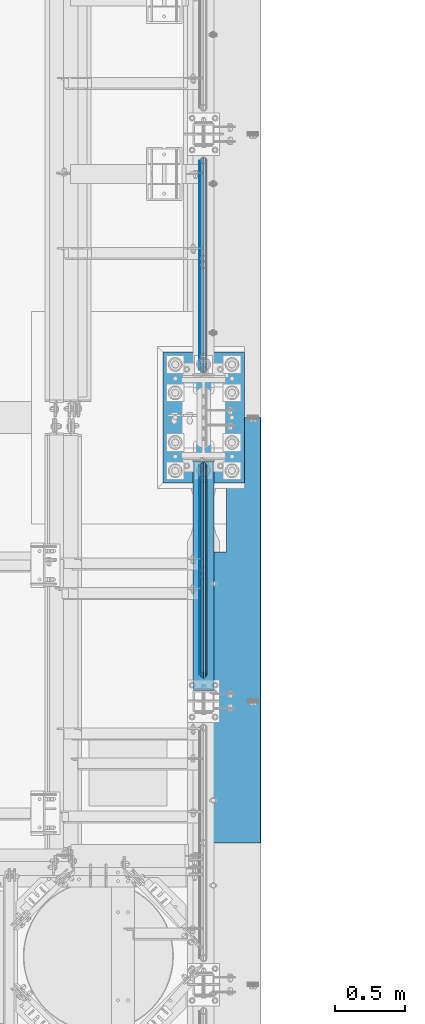
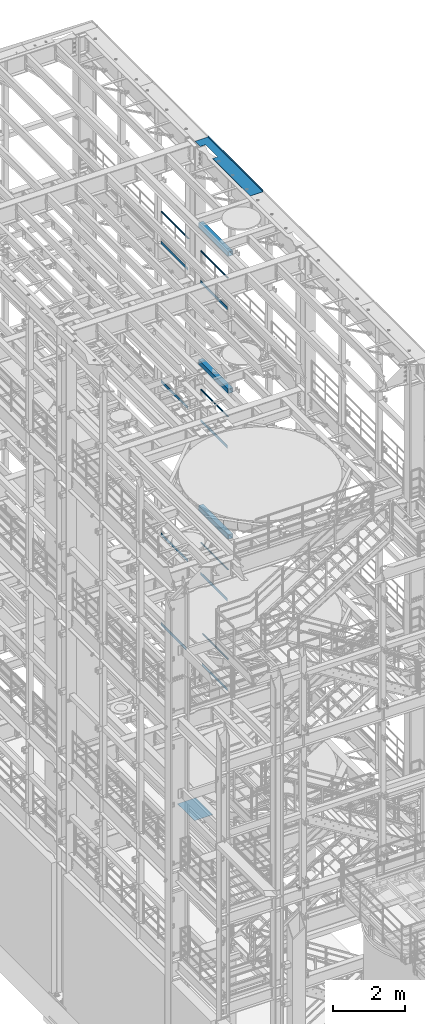
# One storey, part 1076 of 1876: 18 beams, 13 elements without a shape of their own.
"""IFC2X3 building model written with IfcOpenShell, lengths in millimetres."""

from ifc_helpers import new_model, si_unit, frame, origin_with_axes, place, context, subcontext, project, spatial, faceted_brep, material, type_object, element, aggregate, save


model = new_model("IFC2X3")

# Units and contexts
model_context = context("Model", 3, precision=1e-05, world=origin_with_axes())
body_context = subcontext(model_context, "Body", "Model", "MODEL_VIEW")
ifc_project = project(units=[si_unit("LENGTHUNIT", "METRE", prefix="MILLI"), si_unit("AREAUNIT", "SQUARE_METRE"), si_unit("VOLUMEUNIT", "CUBIC_METRE"), si_unit("MASSUNIT", "GRAM", prefix="KILO"), si_unit("TIMEUNIT", "SECOND"), si_unit("PLANEANGLEUNIT", "RADIAN"), si_unit("SOLIDANGLEUNIT", "STERADIAN"), si_unit("THERMODYNAMICTEMPERATUREUNIT", "DEGREE_CELSIUS"), si_unit("LUMINOUSINTENSITYUNIT", "LUMEN")], contexts=[model_context])

# Site, building, storey
site_placement = place(None, origin_with_axes())
site = spatial("IfcSite", under=ifc_project, at=site_placement, CompositionType="ELEMENT")
building_placement = place(site_placement, origin_with_axes())
building = spatial("IfcBuilding", under=site, at=building_placement, Name="Undefined", CompositionType="ELEMENT")
storey_placement = place(building_placement, origin_with_axes())
storey = spatial("IfcBuildingStorey", under=building, at=storey_placement, Name="Undefined", CompositionType="ELEMENT", Elevation=0.0)

# Assembly, beam
assembly_1_placement = place(storey_placement, origin_with_axes())
assembly_1 = element("IfcElementAssembly", 1, at=assembly_1_placement, inside=storey, Name="RAIL", AssemblyPlace="NOTDEFINED", PredefinedType="RIGID_FRAME")
ifc_material_1 = material()
beam_type_1 = type_object("IfcBeamType", Name="PIPE1-1/2SCH40", PredefinedType="NOTDEFINED")
beam_1_placement = place(assembly_1_placement, frame((7620.0, 7940.675, 19059.525), z_axis=(0.0, 0.0, -1.0), x_axis=(0.0, 1.0, 0.0)))
beam_1 = element("IfcBeam", 2, at=beam_1_placement, type_object=beam_type_1, material=ifc_material_1, Name="RAIL", ObjectType="PIPE1-1/2SCH40", context=body_context, shape_type="Brep", body=[
    faceted_brep([(24.1300000000001, -20.4469999999999, 0.0), (34.3535000000002, -17.7076214311803, 10.2235000000001), (1511.8715, -17.7076214311801, 10.2235000000001), (1522.095, -20.4470000000001, 0.0), (41.8376214311802, -10.2235000000001, 17.7076214311819), (1504.38737856882, -10.2235000000001, 17.7076214311819), (44.5770000000002, 0.0, 20.4470000000001), (1501.648, 0.0, 20.4470000000001), (41.8376214311802, 10.2235000000001, 17.7076214311819), (1504.38737856882, 10.2235000000001, 17.7076214311819), (34.3535000000002, 17.7076214311803, 10.2235000000001), (1511.8715, 17.7076214311801, 10.2235000000001), (24.1300000000001, 20.4469999999999, 0.0), (1522.095, 20.4470000000001, 0.0), (13.9065000000001, 17.7076214311803, -10.2235000000001), (1532.3185, 17.7076214311801, -10.2235000000001), (6.42237856882002, 10.2235000000001, -17.7076214311819), (1539.80262143118, 10.2235000000001, -17.7076214311819), (3.68299999999999, 0.0, -20.4470000000001), (1542.542, 0.0, -20.4470000000001), (6.42237856882002, -10.2235000000001, -17.7076214311819), (1539.80262143118, -10.2235000000001, -17.7076214311819), (13.9065000000001, -17.7076214311803, -10.2235000000001), (1532.3185, -17.7076214311801, -10.2235000000001), (24.1299999999854, -24.1299999999992, 0.0), (12.0650000000064, -20.8971929933177, -12.0649999999987), (1534.16, -20.8971929933186, -12.0649999999987), (1522.095, -24.1300000000001, 0.0), (3.23280700668147, -12.0650000000001, -20.8971929933177), (1542.99219299332, -12.0649999999996, -20.8971929933177), (-1.45519152283669e-11, 0.0, -24.130000000001), (1546.225, 0.0, -24.130000000001), (3.23280700668147, 12.0650000000001, -20.8971929933177), (1542.99219299332, 12.0649999999996, -20.8971929933177), (12.0650000000064, 20.8971929933177, -12.0649999999987), (1534.16, 20.8971929933186, -12.0649999999987), (24.1300000000047, 24.1299999999992, 0.0), (1522.095, 24.1300000000001, 0.0), (36.1949999999997, 20.8971929933184, 12.0649999999987), (1510.03, 20.8971929933186, 12.0649999999987), (45.0271929933187, 12.0650000000001, 20.8971929933177), (1501.19780700668, 12.0649999999996, 20.8971929933177), (48.2600000000002, 0.0, 24.130000000001), (1497.965, 0.0, 24.130000000001), (45.0271929933187, -12.0650000000001, 20.8971929933177), (1501.19780700668, -12.0649999999996, 20.8971929933177), (36.1949999999997, -20.8971929933184, 12.0649999999987), (1510.03, -20.8971929933186, 12.0649999999987)], [[[0, 1, 2, 3]], [[1, 4, 5, 2]], [[4, 6, 7, 5]], [[6, 8, 9, 7]], [[8, 10, 11, 9]], [[10, 12, 13, 11]], [[12, 14, 15, 13]], [[14, 16, 17, 15]], [[16, 18, 19, 17]], [[18, 20, 21, 19]], [[20, 22, 23, 21]], [[22, 0, 3, 23]], [[24, 25, 26, 27]], [[25, 28, 29, 26]], [[28, 30, 31, 29]], [[30, 32, 33, 31]], [[32, 34, 35, 33]], [[34, 36, 37, 35]], [[36, 38, 39, 37]], [[38, 40, 41, 39]], [[40, 42, 43, 41]], [[42, 44, 45, 43]], [[44, 46, 47, 45]], [[46, 24, 27, 47]], [[29, 31, 33, 35, 37, 39, 41, 43, 45, 47, 27, 26], [5, 7, 9, 11, 13, 15, 17, 19, 21, 23, 3, 2]], [[46, 44, 42, 40, 38, 36, 34, 32, 30, 28, 25, 24], [22, 20, 18, 16, 14, 12, 10, 8, 6, 4, 1, 0]]]),
])

assembly_2_placement = place(storey_placement, origin_with_axes())
assembly_2 = element("IfcElementAssembly", 3, at=assembly_2_placement, inside=storey, Name="RAIL", AssemblyPlace="NOTDEFINED", PredefinedType="RIGID_FRAME")
beam_2_placement = place(assembly_2_placement, frame((7620.0, 5753.1, 19059.525), z_axis=(0.0, 0.0, -1.0), x_axis=(0.0, 1.0, 0.0)))
beam_2 = element("IfcBeam", 4, at=beam_2_placement, type_object=beam_type_1, material=ifc_material_1, Name="RAIL", ObjectType="PIPE1-1/2SCH40", context=body_context, shape_type="Brep", body=[
    faceted_brep([(24.1300000000001, -20.4469999999999, 0.0), (34.3535000000002, -17.7076214311803, 10.2235000000001), (1511.8715, -17.7076214311801, 10.2235000000001), (1522.095, -20.4470000000001, 0.0), (41.8376214311802, -10.2235000000001, 17.7076214311819), (1504.38737856882, -10.2235000000001, 17.7076214311819), (44.5770000000002, 0.0, 20.4470000000001), (1501.648, 0.0, 20.4470000000001), (41.8376214311802, 10.2235000000001, 17.7076214311819), (1504.38737856882, 10.2235000000001, 17.7076214311819), (34.3535000000002, 17.7076214311803, 10.2235000000001), (1511.8715, 17.7076214311801, 10.2235000000001), (24.1300000000001, 20.4469999999999, 0.0), (1522.095, 20.4470000000001, 0.0), (13.9065000000001, 17.7076214311803, -10.2235000000001), (1532.3185, 17.7076214311801, -10.2235000000001), (6.42237856882002, 10.2235000000001, -17.7076214311819), (1539.80262143118, 10.2235000000001, -17.7076214311819), (3.68299999999999, 0.0, -20.4470000000001), (1542.542, 0.0, -20.4470000000001), (6.42237856882002, -10.2235000000001, -17.7076214311819), (1539.80262143118, -10.2235000000001, -17.7076214311819), (13.9065000000001, -17.7076214311803, -10.2235000000001), (1532.3185, -17.7076214311801, -10.2235000000001), (24.1299999999854, -24.1299999999992, 0.0), (12.0650000000064, -20.8971929933177, -12.0649999999987), (1534.16, -20.8971929933186, -12.0649999999987), (1522.095, -24.1300000000001, 0.0), (3.23280700668147, -12.0650000000001, -20.8971929933177), (1542.99219299332, -12.0649999999996, -20.8971929933177), (-1.45519152283669e-11, 0.0, -24.130000000001), (1546.225, 0.0, -24.130000000001), (3.23280700668147, 12.0650000000001, -20.8971929933177), (1542.99219299332, 12.0649999999996, -20.8971929933177), (12.0650000000064, 20.8971929933177, -12.0649999999987), (1534.16, 20.8971929933186, -12.0649999999987), (24.1300000000047, 24.1299999999992, 0.0), (1522.095, 24.1300000000001, 0.0), (36.1949999999997, 20.8971929933184, 12.0649999999987), (1510.03, 20.8971929933186, 12.0649999999987), (45.0271929933187, 12.0650000000001, 20.8971929933177), (1501.19780700668, 12.0649999999996, 20.8971929933177), (48.2600000000002, 0.0, 24.130000000001), (1497.965, 0.0, 24.130000000001), (45.0271929933187, -12.0650000000001, 20.8971929933177), (1501.19780700668, -12.0649999999996, 20.8971929933177), (36.1949999999997, -20.8971929933184, 12.0649999999987), (1510.03, -20.8971929933186, 12.0649999999987)], [[[0, 1, 2, 3]], [[1, 4, 5, 2]], [[4, 6, 7, 5]], [[6, 8, 9, 7]], [[8, 10, 11, 9]], [[10, 12, 13, 11]], [[12, 14, 15, 13]], [[14, 16, 17, 15]], [[16, 18, 19, 17]], [[18, 20, 21, 19]], [[20, 22, 23, 21]], [[22, 0, 3, 23]], [[24, 25, 26, 27]], [[25, 28, 29, 26]], [[28, 30, 31, 29]], [[30, 32, 33, 31]], [[32, 34, 35, 33]], [[34, 36, 37, 35]], [[36, 38, 39, 37]], [[38, 40, 41, 39]], [[40, 42, 43, 41]], [[42, 44, 45, 43]], [[44, 46, 47, 45]], [[46, 24, 27, 47]], [[29, 31, 33, 35, 37, 39, 41, 43, 45, 47, 27, 26], [5, 7, 9, 11, 13, 15, 17, 19, 21, 23, 3, 2]], [[46, 44, 42, 40, 38, 36, 34, 32, 30, 28, 25, 24], [22, 20, 18, 16, 14, 12, 10, 8, 6, 4, 1, 0]]]),
])

assembly_3_placement = place(storey_placement, origin_with_axes())
assembly_3 = element("IfcElementAssembly", 5, at=assembly_3_placement, inside=storey, Name="RAIL", AssemblyPlace="NOTDEFINED", PredefinedType="RIGID_FRAME")
beam_3_placement = place(assembly_3_placement, frame((7620.0, 5753.1, 14385.925), z_axis=(0.0, 0.0, -1.0), x_axis=(0.0, 1.0, 0.0)))
beam_3 = element("IfcBeam", 6, at=beam_3_placement, type_object=beam_type_1, material=ifc_material_1, Name="RAIL", ObjectType="PIPE1-1/2SCH40", context=body_context, shape_type="Brep", body=[
    faceted_brep([(24.1300000000001, -20.4469999999999, 0.0), (34.3535000000002, -17.7076214311803, 10.2235000000001), (1511.8715, -17.7076214311801, 10.2235000000001), (1522.095, -20.4470000000001, 0.0), (41.8376214311802, -10.2235000000001, 17.7076214311819), (1504.38737856882, -10.2235000000001, 17.7076214311819), (44.5770000000002, 0.0, 20.4470000000001), (1501.648, 0.0, 20.4470000000001), (41.8376214311802, 10.2235000000001, 17.7076214311819), (1504.38737856882, 10.2235000000001, 17.7076214311819), (34.3535000000002, 17.7076214311803, 10.2235000000001), (1511.8715, 17.7076214311801, 10.2235000000001), (24.1300000000001, 20.4469999999999, 0.0), (1522.095, 20.4470000000001, 0.0), (13.9065000000001, 17.7076214311803, -10.2235000000001), (1532.3185, 17.7076214311801, -10.2235000000001), (6.42237856882002, 10.2235000000001, -17.7076214311819), (1539.80262143118, 10.2235000000001, -17.7076214311819), (3.68299999999999, 0.0, -20.4470000000001), (1542.542, 0.0, -20.4470000000001), (6.42237856882002, -10.2235000000001, -17.7076214311819), (1539.80262143118, -10.2235000000001, -17.7076214311819), (13.9065000000001, -17.7076214311803, -10.2235000000001), (1532.3185, -17.7076214311801, -10.2235000000001), (24.1299999999854, -24.1299999999992, 0.0), (12.0650000000064, -20.8971929933177, -12.0649999999987), (1534.16, -20.8971929933186, -12.0649999999987), (1522.095, -24.1300000000001, 0.0), (3.23280700668147, -12.0650000000001, -20.8971929933177), (1542.99219299332, -12.0649999999996, -20.8971929933177), (-1.45519152283669e-11, 0.0, -24.130000000001), (1546.225, 0.0, -24.130000000001), (3.23280700668147, 12.0650000000001, -20.8971929933177), (1542.99219299332, 12.0649999999996, -20.8971929933177), (12.0650000000064, 20.8971929933177, -12.0649999999987), (1534.16, 20.8971929933186, -12.0649999999987), (24.1300000000047, 24.1299999999992, 0.0), (1522.095, 24.1300000000001, 0.0), (36.1949999999997, 20.8971929933184, 12.0649999999987), (1510.03, 20.8971929933186, 12.0649999999987), (45.0271929933187, 12.0650000000001, 20.8971929933177), (1501.19780700668, 12.0649999999996, 20.8971929933177), (48.2600000000002, 0.0, 24.130000000001), (1497.965, 0.0, 24.130000000001), (45.0271929933187, -12.0650000000001, 20.8971929933177), (1501.19780700668, -12.0649999999996, 20.8971929933177), (36.1949999999997, -20.8971929933184, 12.0649999999987), (1510.03, -20.8971929933186, 12.0649999999987)], [[[0, 1, 2, 3]], [[1, 4, 5, 2]], [[4, 6, 7, 5]], [[6, 8, 9, 7]], [[8, 10, 11, 9]], [[10, 12, 13, 11]], [[12, 14, 15, 13]], [[14, 16, 17, 15]], [[16, 18, 19, 17]], [[18, 20, 21, 19]], [[20, 22, 23, 21]], [[22, 0, 3, 23]], [[24, 25, 26, 27]], [[25, 28, 29, 26]], [[28, 30, 31, 29]], [[30, 32, 33, 31]], [[32, 34, 35, 33]], [[34, 36, 37, 35]], [[36, 38, 39, 37]], [[38, 40, 41, 39]], [[40, 42, 43, 41]], [[42, 44, 45, 43]], [[44, 46, 47, 45]], [[46, 24, 27, 47]], [[29, 31, 33, 35, 37, 39, 41, 43, 45, 47, 27, 26], [5, 7, 9, 11, 13, 15, 17, 19, 21, 23, 3, 2]], [[46, 44, 42, 40, 38, 36, 34, 32, 30, 28, 25, 24], [22, 20, 18, 16, 14, 12, 10, 8, 6, 4, 1, 0]]]),
])

assembly_4_placement = place(storey_placement, origin_with_axes())
assembly_4 = element("IfcElementAssembly", 7, at=assembly_4_placement, inside=storey, Name="RAIL", AssemblyPlace="NOTDEFINED", PredefinedType="RIGID_FRAME")
beam_4_placement = place(assembly_4_placement, frame((7620.0, 5753.1, 9229.725), z_axis=(0.0, 0.0, -1.0), x_axis=(0.0, 1.0, 0.0)))
beam_4 = element("IfcBeam", 8, at=beam_4_placement, type_object=beam_type_1, material=ifc_material_1, Name="RAIL", ObjectType="PIPE1-1/2SCH40", context=body_context, shape_type="Brep", body=[
    faceted_brep([(24.1300000000001, -20.4469999999999, 0.0), (34.3535000000002, -17.7076214311803, 10.2235000000001), (1511.8715, -17.7076214311801, 10.2235000000001), (1522.095, -20.4470000000001, 0.0), (41.8376214311802, -10.2235000000001, 17.7076214311819), (1504.38737856882, -10.2235000000001, 17.7076214311819), (44.5770000000002, 0.0, 20.4470000000001), (1501.648, 0.0, 20.4470000000001), (41.8376214311802, 10.2235000000001, 17.7076214311819), (1504.38737856882, 10.2235000000001, 17.7076214311819), (34.3535000000002, 17.7076214311803, 10.2235000000001), (1511.8715, 17.7076214311801, 10.2235000000001), (24.1300000000001, 20.4469999999999, 0.0), (1522.095, 20.4470000000001, 0.0), (13.9065000000001, 17.7076214311803, -10.2235000000001), (1532.3185, 17.7076214311801, -10.2235000000001), (6.42237856882002, 10.2235000000001, -17.7076214311819), (1539.80262143118, 10.2235000000001, -17.7076214311819), (3.68299999999999, 0.0, -20.4470000000001), (1542.542, 0.0, -20.4470000000001), (6.42237856882002, -10.2235000000001, -17.7076214311819), (1539.80262143118, -10.2235000000001, -17.7076214311819), (13.9065000000001, -17.7076214311803, -10.2235000000001), (1532.3185, -17.7076214311801, -10.2235000000001), (24.1299999999854, -24.1299999999992, 0.0), (12.0650000000064, -20.8971929933177, -12.0649999999987), (1534.16, -20.8971929933186, -12.0649999999987), (1522.095, -24.1300000000001, 0.0), (3.23280700668147, -12.0650000000001, -20.8971929933177), (1542.99219299332, -12.0649999999996, -20.8971929933177), (-1.45519152283669e-11, 0.0, -24.130000000001), (1546.225, 0.0, -24.130000000001), (3.23280700668147, 12.0650000000001, -20.8971929933177), (1542.99219299332, 12.0649999999996, -20.8971929933177), (12.0650000000064, 20.8971929933177, -12.0649999999987), (1534.16, 20.8971929933186, -12.0649999999987), (24.1300000000047, 24.1299999999992, 0.0), (1522.095, 24.1300000000001, 0.0), (36.1949999999997, 20.8971929933184, 12.0649999999987), (1510.03, 20.8971929933186, 12.0649999999987), (45.0271929933187, 12.0650000000001, 20.8971929933177), (1501.19780700668, 12.0649999999996, 20.8971929933177), (48.2600000000002, 0.0, 24.130000000001), (1497.965, 0.0, 24.130000000001), (45.0271929933187, -12.0650000000001, 20.8971929933177), (1501.19780700668, -12.0649999999996, 20.8971929933177), (36.1949999999997, -20.8971929933184, 12.0649999999987), (1510.03, -20.8971929933186, 12.0649999999987)], [[[0, 1, 2, 3]], [[1, 4, 5, 2]], [[4, 6, 7, 5]], [[6, 8, 9, 7]], [[8, 10, 11, 9]], [[10, 12, 13, 11]], [[12, 14, 15, 13]], [[14, 16, 17, 15]], [[16, 18, 19, 17]], [[18, 20, 21, 19]], [[20, 22, 23, 21]], [[22, 0, 3, 23]], [[24, 25, 26, 27]], [[25, 28, 29, 26]], [[28, 30, 31, 29]], [[30, 32, 33, 31]], [[32, 34, 35, 33]], [[34, 36, 37, 35]], [[36, 38, 39, 37]], [[38, 40, 41, 39]], [[40, 42, 43, 41]], [[42, 44, 45, 43]], [[44, 46, 47, 45]], [[46, 24, 27, 47]], [[29, 31, 33, 35, 37, 39, 41, 43, 45, 47, 27, 26], [5, 7, 9, 11, 13, 15, 17, 19, 21, 23, 3, 2]], [[46, 44, 42, 40, 38, 36, 34, 32, 30, 28, 25, 24], [22, 20, 18, 16, 14, 12, 10, 8, 6, 4, 1, 0]]]),
])

assembly_5_placement = place(storey_placement, origin_with_axes())
assembly_5 = element("IfcElementAssembly", 9, at=assembly_5_placement, inside=storey, Name="RAIL", AssemblyPlace="NOTDEFINED", PredefinedType="RIGID_FRAME")
beam_5_placement = place(assembly_5_placement, frame((7620.00000000068, 7204.0396633614, 6207.13724280096), z_axis=(0.0, 7.91400000045761e-06, -0.999999999968684), x_axis=(0.0, -0.999999999968684, -7.91400000071008e-06)))
beam_5 = element("IfcBeam", 10, at=beam_5_placement, type_object=beam_type_1, material=ifc_material_1, Name="RAIL", ObjectType="PIPE1-1/2SCH40", context=body_context, shape_type="Brep", body=[
    faceted_brep([(24.1297889306325, -20.4470000000001, 4.54747350886464e-12), (34.3533782626628, -17.7076214311801, 10.223500000001), (1416.58624781054, -17.7076214311801, 10.2235000002374), (1426.80965847928, -20.4470000000001, 2.42835085373372e-10), (41.8375650894295, -10.2235000000001, 17.7076214311801), (1409.10219177439, -10.2235000000001, 17.7076214314138), (44.5770000000002, 0.0, 20.4470000000001), (1406.3628371418, 0.0, 20.4470000002311), (41.8375650894295, 10.2235000000001, 17.7076214311801), (1409.10219177439, 10.2235000000001, 17.7076214314138), (34.3533782626628, 17.7076214311801, 10.223500000001), (1416.58624781054, 17.7076214311801, 10.2235000002374), (24.1297889306325, 20.4470000000001, 4.54747350886464e-12), (1426.80965847928, 20.4470000000001, 2.42835085373372e-10), (13.9061995986012, 17.7076214311801, -10.2234999999919), (1437.03306914802, 17.7076214311801, -10.2234999997499), (6.42201277183449, 10.2235000000001, -17.707621431171), (1444.51712518418, 10.2235000000001, -17.7076214309263), (3.68261026657001, 0.0, -20.4469999999901), (1447.25647981676, 0.0, -20.4469999997445), (6.42201277183449, -10.2235000000001, -17.707621431171), (1444.51712518418, -10.2235000000001, -17.7076214309263), (13.9061995986012, -17.7076214311801, -10.2234999999919), (1437.03306914802, -17.7076214311801, -10.2234999997499), (24.1297889306325, -24.1300000000001, 4.54747350886464e-12), (12.0646835077378, -20.8971929933186, -12.0649999999923), (1438.8745530573, -20.8971929933186, -12.0649999997486), (1426.80965847928, -24.1300000000001, 2.42835085373372e-10), (3.23241333950409, -12.0649999999996, -20.8971929933086), (1447.70666887637, -12.0649999999996, -20.8971929930613), (-0.000421915156039177, 0.0, -24.1299999999892), (1450.93944763532, 0.0, -24.1299999997409), (3.23241333950409, 12.0649999999996, -20.8971929933086), (1447.70666887637, 12.0649999999996, -20.8971929930613), (12.0646835077378, 20.8971929933186, -12.0649999999923), (1438.8745530573, 20.8971929933186, -12.0649999997486), (24.1297889306325, 24.1300000000001, 4.54747350886464e-12), (1426.80965847928, 24.1300000000001, 2.42835085373372e-10), (36.1948943535272, 20.8971929933186, 12.0650000000014), (1414.74476390127, 20.8971929933186, 12.0650000002352), (45.0271929933187, 12.0650000000001, 20.8971929933177), (1405.9126480822, 12.0649999999996, 20.8971929935497), (48.2600000000002, 0.0, 24.130000000001), (1402.67986932325, 0.0, 24.1300000002293), (45.0271929933187, -12.0650000000001, 20.8971929933177), (1405.9126480822, -12.0649999999996, 20.8971929935497), (36.1948943535263, -20.8971929933186, 12.0650000000014), (1414.74476390127, -20.8971929933186, 12.0650000002352)], [[[0, 1, 2, 3]], [[1, 4, 5, 2]], [[4, 6, 7, 5]], [[6, 8, 9, 7]], [[8, 10, 11, 9]], [[10, 12, 13, 11]], [[12, 14, 15, 13]], [[14, 16, 17, 15]], [[16, 18, 19, 17]], [[18, 20, 21, 19]], [[20, 22, 23, 21]], [[22, 0, 3, 23]], [[24, 25, 26, 27]], [[25, 28, 29, 26]], [[28, 30, 31, 29]], [[30, 32, 33, 31]], [[32, 34, 35, 33]], [[34, 36, 37, 35]], [[36, 38, 39, 37]], [[38, 40, 41, 39]], [[40, 42, 43, 41]], [[42, 44, 45, 43]], [[44, 46, 47, 45]], [[46, 24, 27, 47]], [[29, 31, 33, 35, 37, 39, 41, 43, 45, 47, 27, 26], [5, 7, 9, 11, 13, 15, 17, 19, 21, 23, 3, 2]], [[46, 44, 42, 40, 38, 36, 34, 32, 30, 28, 25, 24], [22, 20, 18, 16, 14, 12, 10, 8, 6, 4, 1, 0]]]),
])

assembly_6_placement = place(storey_placement, origin_with_axes())
assembly_6 = element("IfcElementAssembly", 11, at=assembly_6_placement, inside=storey, Name="BEAM", AssemblyPlace="NOTDEFINED", PredefinedType="RIGID_FRAME")
ifc_material_2 = material()
beam_type_2 = type_object("IfcBeamType", Name="HSS6X6X3/8", PredefinedType="NOTDEFINED")
beam_6_placement = place(assembly_6_placement, frame((7620.0, 5588.0, 19958.05), z_axis=(-1.0, 0.0, 0.0), x_axis=(0.0, 1.0, 0.0)))
beam_6 = element("IfcBeam", 12, at=beam_6_placement, type_object=beam_type_2, material=ifc_material_2, Name="BEAM", ObjectType="HSS6X6X3/8", context=body_context, shape_type="Brep", body=[
    faceted_brep([(76.2000000000007, 66.6749999999993, -66.6750000000002), (76.2000000000007, -66.6749999999993, -66.6750000000002), (1720.85, -66.6749999999993, -66.675), (1720.85, 66.6749999999993, -66.675), (76.2000000000007, -66.6749999999993, 66.6750000000002), (1720.85, -66.6749999999993, 66.675), (76.2000000000007, 66.6749999999993, 66.6750000000002), (1720.85, 66.6749999999993, 66.675), (76.2000000000007, 76.2000000000007, -76.1999999999998), (76.2000000000007, 76.2000000000007, 76.1999999999998), (1720.85, 76.2000000000007, 76.2), (1720.85, 76.2000000000007, -76.2), (76.2000000000007, -76.2000000000007, 76.1999999999998), (1720.85, -76.2000000000007, 76.2), (76.2000000000007, -76.2000000000007, -76.1999999999998), (1720.85, -76.2000000000007, -76.2)], [[[0, 1, 2, 3]], [[1, 4, 5, 2]], [[4, 6, 7, 5]], [[6, 0, 3, 7]], [[8, 9, 10, 11]], [[9, 12, 13, 10]], [[12, 14, 15, 13]], [[14, 8, 11, 15]], [[13, 15, 11, 10], [5, 7, 3, 2]], [[14, 12, 9, 8], [6, 4, 1, 0]]]),
])
aggregate(assembly_6, [beam_6])

assembly_7_placement = place(storey_placement, origin_with_axes())
assembly_7 = element("IfcElementAssembly", 13, at=assembly_7_placement, inside=storey, Name="BEAM", AssemblyPlace="NOTDEFINED", PredefinedType="RIGID_FRAME")
beam_7_placement = place(assembly_7_placement, frame((7620.0, 5588.0, 15335.25), z_axis=(-1.0, 0.0, 0.0), x_axis=(0.0, 1.0, 0.0)))
beam_7 = element("IfcBeam", 14, at=beam_7_placement, type_object=beam_type_2, material=ifc_material_2, Name="BEAM", ObjectType="HSS6X6X3/8", context=body_context, shape_type="Brep", body=[
    faceted_brep([(76.2000000000007, 66.6749999999993, -66.6750000000002), (76.2000000000007, -66.6749999999993, -66.6750000000002), (1720.85, -66.6749999999993, -66.675), (1720.85, 66.6749999999993, -66.675), (76.2000000000007, -66.6749999999993, 66.6750000000002), (1720.85, -66.6749999999993, 66.675), (76.2000000000007, 66.6749999999993, 66.6750000000002), (1720.85, 66.6749999999993, 66.675), (76.2000000000007, 76.2000000000007, -76.1999999999998), (76.2000000000007, 76.2000000000007, 76.1999999999998), (1720.85, 76.2000000000007, 76.2), (1720.85, 76.2000000000007, -76.2), (76.2000000000007, -76.2000000000007, 76.1999999999998), (1720.85, -76.2000000000007, 76.2), (76.2000000000007, -76.2000000000007, -76.1999999999998), (1720.85, -76.2000000000007, -76.2)], [[[0, 1, 2, 3]], [[1, 4, 5, 2]], [[4, 6, 7, 5]], [[6, 0, 3, 7]], [[8, 9, 10, 11]], [[9, 12, 13, 10]], [[12, 14, 15, 13]], [[14, 8, 11, 15]], [[13, 15, 11, 10], [5, 7, 3, 2]], [[14, 12, 9, 8], [6, 4, 1, 0]]]),
])
aggregate(assembly_7, [beam_7])

assembly_8_placement = place(storey_placement, origin_with_axes())
assembly_8 = element("IfcElementAssembly", 15, at=assembly_8_placement, inside=storey, Name="BEAM", AssemblyPlace="NOTDEFINED", PredefinedType="RIGID_FRAME")
beam_8_placement = place(assembly_8_placement, frame((7620.0, 5588.0, 10420.35), z_axis=(-1.0, 0.0, 0.0), x_axis=(0.0, 1.0, 0.0)))
beam_8 = element("IfcBeam", 16, at=beam_8_placement, type_object=beam_type_2, material=ifc_material_2, Name="BEAM", ObjectType="HSS6X6X3/8", context=body_context, shape_type="Brep", body=[
    faceted_brep([(76.2000000000007, 66.6749999999993, -66.6750000000002), (76.2000000000007, -66.6749999999993, -66.6750000000002), (1720.85, -66.6749999999993, -66.675), (1720.85, 66.6749999999993, -66.675), (76.2000000000007, -66.6749999999993, 66.6750000000002), (1720.85, -66.6749999999993, 66.675), (76.2000000000007, 66.6749999999993, 66.6750000000002), (1720.85, 66.6749999999993, 66.675), (76.2000000000007, 76.2000000000007, -76.1999999999998), (76.2000000000007, 76.2000000000007, 76.1999999999998), (1720.85, 76.2000000000007, 76.2), (1720.85, 76.2000000000007, -76.2), (76.2000000000007, -76.2000000000007, 76.1999999999998), (1720.85, -76.2000000000007, 76.2), (76.2000000000007, -76.2000000000007, -76.1999999999998), (1720.85, -76.2000000000007, -76.2)], [[[0, 1, 2, 3]], [[1, 4, 5, 2]], [[4, 6, 7, 5]], [[6, 0, 3, 7]], [[8, 9, 10, 11]], [[9, 12, 13, 10]], [[12, 14, 15, 13]], [[14, 8, 11, 15]], [[13, 15, 11, 10], [5, 7, 3, 2]], [[14, 12, 9, 8], [6, 4, 1, 0]]]),
])
aggregate(assembly_8, [beam_8])

# Beam
ifc_material_3 = material(Name="STEEL/A36")
beam_type_3 = type_object("IfcBeamType", PredefinedType="NOTDEFINED")
beam_9_placement = place(assembly_1_placement, frame((7592.69500000001, 7964.805, 18049.875), z_axis=(0.0, 0.0, 1.0), x_axis=(0.0, 1.0, 0.0)))
beam_9 = element("IfcBeam", 17, at=beam_9_placement, type_object=beam_type_3, material=ifc_material_3, Name="PLATE", context=body_context, shape_type="Brep", body=[
    faceted_brep([(0.0, 3.17500000000018, -50.8000000000002), (0.0, 3.17500000000018, 50.8000000000002), (1497.965, 3.175, 50.7999999999993), (1497.965, 3.175, -50.7999999999993), (0.0, -3.17500000000018, 50.8000000000002), (1497.965, -3.175, 50.7999999999993), (0.0, -3.17500000000018, -50.8000000000002), (1497.965, -3.175, -50.7999999999993)], [[[0, 1, 2, 3]], [[1, 4, 5, 2]], [[4, 6, 7, 5]], [[6, 0, 3, 7]], [[5, 7, 3, 2]], [[6, 4, 1, 0]]]),
])

aggregate(assembly_1, [beam_9, beam_1])

beam_10_placement = place(assembly_2_placement, frame((7592.69500000001, 5777.23, 18049.8809122948), z_axis=(0.0, 0.0, 1.0), x_axis=(0.0, 1.0, 0.0)))
beam_10 = element("IfcBeam", 18, at=beam_10_placement, type_object=beam_type_3, material=ifc_material_3, Name="PLATE", context=body_context, shape_type="Brep", body=[
    faceted_brep([(0.0, 3.17500000000018, -50.8000000000002), (0.0, 3.17500000000018, 50.8000000000002), (1497.965, 3.175, 50.7999999999993), (1497.965, 3.175, -50.7999999999993), (0.0, -3.17500000000018, 50.8000000000002), (1497.965, -3.175, 50.7999999999993), (0.0, -3.17500000000018, -50.8000000000002), (1497.965, -3.175, -50.7999999999993)], [[[0, 1, 2, 3]], [[1, 4, 5, 2]], [[4, 6, 7, 5]], [[6, 0, 3, 7]], [[5, 7, 3, 2]], [[6, 4, 1, 0]]]),
])

aggregate(assembly_2, [beam_10, beam_2])

# Assembly, beam
assembly_9_placement = place(storey_placement, origin_with_axes())
assembly_9 = element("IfcElementAssembly", 19, at=assembly_9_placement, inside=storey, Name="RAIL", AssemblyPlace="NOTDEFINED", PredefinedType="RIGID_FRAME")
beam_11_placement = place(assembly_9_placement, frame((7592.69500000001, 7964.805, 13376.275), z_axis=(0.0, 0.0, 1.0), x_axis=(0.0, 1.0, 0.0)))
beam_11 = element("IfcBeam", 20, at=beam_11_placement, type_object=beam_type_3, material=ifc_material_3, Name="PLATE", context=body_context, shape_type="Brep", body=[
    faceted_brep([(0.0, 3.17500000000018, -50.8000000000002), (0.0, 3.17500000000018, 50.8000000000002), (1497.965, 3.175, 50.7999999999993), (1497.965, 3.175, -50.7999999999993), (0.0, -3.17500000000018, 50.8000000000002), (1497.965, -3.175, 50.7999999999993), (0.0, -3.17500000000018, -50.8000000000002), (1497.965, -3.175, -50.7999999999993)], [[[0, 1, 2, 3]], [[1, 4, 5, 2]], [[4, 6, 7, 5]], [[6, 0, 3, 7]], [[5, 7, 3, 2]], [[6, 4, 1, 0]]]),
])
aggregate(assembly_9, [beam_11])

# Beam
beam_12_placement = place(assembly_3_placement, frame((7592.69500000001, 5777.23, 13376.2809122948), z_axis=(0.0, 0.0, 1.0), x_axis=(0.0, 1.0, 0.0)))
beam_12 = element("IfcBeam", 21, at=beam_12_placement, type_object=beam_type_3, material=ifc_material_3, Name="PLATE", context=body_context, shape_type="Brep", body=[
    faceted_brep([(0.0, 3.17500000000018, -50.8000000000002), (0.0, 3.17500000000018, 50.8000000000002), (1497.965, 3.175, 50.7999999999993), (1497.965, 3.175, -50.7999999999993), (0.0, -3.17500000000018, 50.8000000000002), (1497.965, -3.175, 50.7999999999993), (0.0, -3.17500000000018, -50.8000000000002), (1497.965, -3.175, -50.7999999999993)], [[[0, 1, 2, 3]], [[1, 4, 5, 2]], [[4, 6, 7, 5]], [[6, 0, 3, 7]], [[5, 7, 3, 2]], [[6, 4, 1, 0]]]),
])

aggregate(assembly_3, [beam_12, beam_3])

# Assembly, beam
assembly_10_placement = place(storey_placement, origin_with_axes())
assembly_10 = element("IfcElementAssembly", 22, at=assembly_10_placement, inside=storey, Name="RAIL", AssemblyPlace="NOTDEFINED", PredefinedType="RIGID_FRAME")
beam_13_placement = place(assembly_10_placement, frame((7592.69500000001, 7964.805, 8220.07500000001), z_axis=(0.0, 0.0, 1.0), x_axis=(0.0, 1.0, 0.0)))
beam_13 = element("IfcBeam", 23, at=beam_13_placement, type_object=beam_type_3, material=ifc_material_3, Name="PLATE", context=body_context, shape_type="Brep", body=[
    faceted_brep([(0.0, 3.17500000000018, -50.8000000000002), (0.0, 3.17500000000018, 50.8000000000002), (1497.965, 3.175, 50.7999999999993), (1497.965, 3.175, -50.7999999999993), (0.0, -3.17500000000018, 50.8000000000002), (1497.965, -3.175, 50.7999999999993), (0.0, -3.17500000000018, -50.8000000000002), (1497.965, -3.175, -50.7999999999993)], [[[0, 1, 2, 3]], [[1, 4, 5, 2]], [[4, 6, 7, 5]], [[6, 0, 3, 7]], [[5, 7, 3, 2]], [[6, 4, 1, 0]]]),
])
aggregate(assembly_10, [beam_13])

# Beam
beam_14_placement = place(assembly_4_placement, frame((7592.69500000001, 5777.23, 8220.08091229478), z_axis=(0.0, 0.0, 1.0), x_axis=(0.0, 1.0, 0.0)))
beam_14 = element("IfcBeam", 24, at=beam_14_placement, type_object=beam_type_3, material=ifc_material_3, Name="PLATE", context=body_context, shape_type="Brep", body=[
    faceted_brep([(0.0, 3.17500000000018, -50.8000000000002), (0.0, 3.17500000000018, 50.8000000000002), (1497.965, 3.175, 50.7999999999993), (1497.965, 3.175, -50.7999999999993), (0.0, -3.17500000000018, 50.8000000000002), (1497.965, -3.175, 50.7999999999993), (0.0, -3.17500000000018, -50.8000000000002), (1497.965, -3.175, -50.7999999999993)], [[[0, 1, 2, 3]], [[1, 4, 5, 2]], [[4, 6, 7, 5]], [[6, 0, 3, 7]], [[5, 7, 3, 2]], [[6, 4, 1, 0]]]),
])

aggregate(assembly_4, [beam_14, beam_4])

# Assembly, beam
assembly_11_placement = place(storey_placement, origin_with_axes())
assembly_11 = element("IfcElementAssembly", 25, at=assembly_11_placement, inside=storey, Name="RAIL", AssemblyPlace="NOTDEFINED", PredefinedType="RIGID_FRAME")
beam_15_placement = place(assembly_11_placement, frame((7592.69500000001, 8060.055, 5197.475), z_axis=(0.0, 0.0, 1.0), x_axis=(0.0, 1.0, 0.0)))
beam_15 = element("IfcBeam", 26, at=beam_15_placement, type_object=beam_type_3, material=ifc_material_3, Name="PLATE", context=body_context, shape_type="Brep", body=[
    faceted_brep([(0.0, 3.17500000000018, -50.8000000000002), (0.0, 3.17500000000018, 50.8000000000002), (1402.715, 3.175, 50.8000000000002), (1402.715, 3.175, -50.8000000000002), (0.0, -3.17500000000018, 50.8000000000002), (1402.715, -3.175, 50.8000000000002), (0.0, -3.17500000000018, -50.8000000000002), (1402.715, -3.175, -50.8000000000002)], [[[0, 1, 2, 3]], [[1, 4, 5, 2]], [[4, 6, 7, 5]], [[6, 0, 3, 7]], [[5, 7, 3, 2]], [[6, 4, 1, 0]]]),
])
aggregate(assembly_11, [beam_15])

# Beam
beam_16_placement = place(assembly_5_placement, frame((7592.69500000001, 5777.23, 5197.48091229478), z_axis=(0.0, 0.0, 1.0), x_axis=(0.0, 1.0, 0.0)))
beam_16 = element("IfcBeam", 27, at=beam_16_placement, type_object=beam_type_3, material=ifc_material_3, Name="PLATE", context=body_context, shape_type="Brep", body=[
    faceted_brep([(0.0, 3.17500000000018, -50.8000000000002), (0.0, 3.17500000000018, 50.8000000000002), (1402.6796633614, 3.175, 50.8000000000002), (1402.6796633614, 3.175, -50.8000000000002), (0.0, -3.17500000000018, 50.8000000000002), (1402.6796633614, -3.175, 50.8000000000002), (0.0, -3.17500000000018, -50.8000000000002), (1402.6796633614, -3.175, -50.8000000000002)], [[[0, 1, 2, 3]], [[1, 4, 5, 2]], [[4, 6, 7, 5]], [[6, 0, 3, 7]], [[5, 7, 3, 2]], [[6, 4, 1, 0]]]),
])

aggregate(assembly_5, [beam_16, beam_5])

# Assembly, beam
assembly_12_placement = place(storey_placement, origin_with_axes())
assembly_12 = element("IfcElementAssembly", 28, at=assembly_12_placement, inside=storey, Name="BENT PLATE", AssemblyPlace="NOTDEFINED", PredefinedType="RIGID_FRAME")
beam_type_4 = type_object("IfcBeamType", PredefinedType="NOTDEFINED")
beam_17_placement = place(assembly_12_placement, frame((7619.99998321378, 6096.0, 22558.375), z_axis=(0.0, 1.0, 0.0), x_axis=(0.999999999986024, 0.0, -5.28699999861059e-06)))
beam_17 = element("IfcBeam", 29, at=beam_17_placement, type_object=beam_type_4, material=ifc_material_3, Name="BENT PLATE", context=body_context, shape_type="Brep", body=[
    faceted_brep([(165.10005182243, -3.17500005134207, 561.975000000002), (165.100006108781, 3.17499994866375, 561.975000000002), (9.87827514231654e-10, 3.17499999999927, 561.975000000002), (-9.87827486476078e-10, -3.17500000000291, 561.975000000002), (165.10005182243, -3.17500005134207, 1235.07497558594), (165.100006108781, 3.17499994866375, 1235.07497558594), (-9.87827486476078e-10, -3.17500000000291, 1235.07497558594), (9.87827514231654e-10, 3.17499999999927, 1235.07497558594), (406.399963385245, -3.17500000258951, 1524.0), (406.399963385245, -3.17500000258951, -1524.0), (406.399980137296, -63.5005739318367, -1524.0), (406.399980137296, -63.5005739318367, 1524.0), (412.74996162189, 3.17499999736538, 1524.0), (-9.88620740827173e-10, 3.17500000000291, 1524.0), (9.877112461254e-10, -3.17499999999563, 1524.0), (412.749980137296, -63.5005721684938, 1524.0), (412.74996162189, 3.17499999736538, -1524.0), (412.749980137296, -63.5005721684938, -1524.0), (9.877112461254e-10, -3.17499999999563, -1524.0), (-9.88620740827173e-10, 3.17500000000291, -1524.0)], [[[0, 1, 2, 3]], [[4, 5, 1, 0]], [[6, 7, 5, 4]], [[8, 9, 10, 11]], [[12, 13, 14, 8, 11, 15]], [[16, 12, 15, 17]], [[11, 10, 17, 15]], [[9, 18, 19, 16, 17, 10]], [[19, 18, 3, 2]], [[13, 12, 16, 19, 2, 1, 5, 7]], [[14, 13, 7, 6]], [[3, 18, 9, 8, 14, 6, 4, 0]]]),
])
aggregate(assembly_12, [beam_17])

assembly_13_placement = place(storey_placement, origin_with_axes())
assembly_13 = element("IfcElementAssembly", 30, at=assembly_13_placement, inside=storey, Name="TEMPLATE", AssemblyPlace="NOTDEFINED", PredefinedType="RIGID_FRAME")
beam_type_5 = type_object("IfcBeamType", PredefinedType="NOTDEFINED")
beam_18_placement = place(assembly_13_placement, frame((7620.0, 7150.1, 40.4815), z_axis=(-1.0, 0.0, 0.0), x_axis=(0.0, 1.0, 0.0)))
beam_18 = element("IfcBeam", 31, at=beam_18_placement, type_object=beam_type_5, material=ifc_material_3, Name="TEMPLATE", context=body_context, shape_type="Brep", body=[
    faceted_brep([(0.0, 2.3815, -292.1), (0.0, 2.3815, 292.1), (939.8, 2.3815, 292.1), (939.8, 2.3815, -292.1), (0.0, -2.3815, 292.1), (939.8, -2.3815, 292.1), (0.0, -2.3815, -292.1), (939.8, -2.3815, -292.1)], [[[0, 1, 2, 3]], [[1, 4, 5, 2]], [[4, 6, 7, 5]], [[6, 0, 3, 7]], [[5, 7, 3, 2]], [[6, 4, 1, 0]]]),
])
aggregate(assembly_13, [beam_18])

save(model, "model.ifc")
